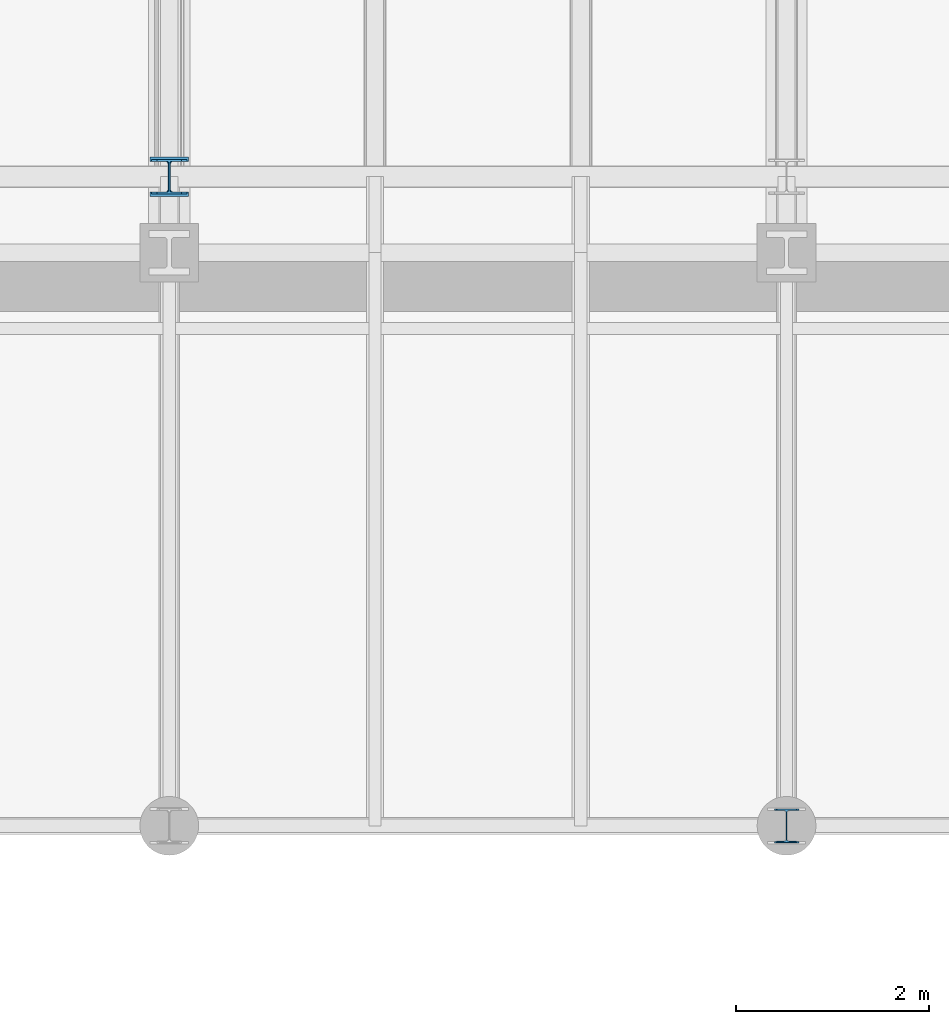
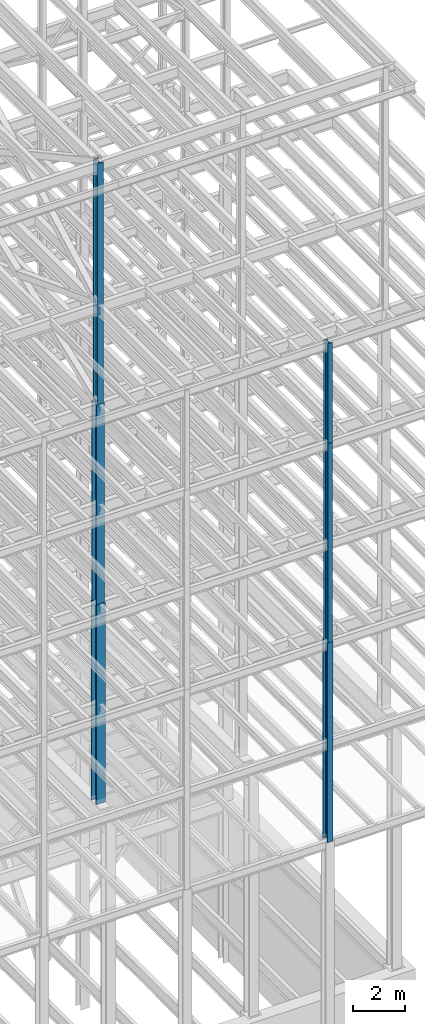
# One storey, part 80 of 150: 6 columns.
"""IFC2X3 building model written with IfcOpenShell, lengths in millimetres."""

from ifc_helpers import new_model, si_unit, frame, origin_with_axes, origin_2d_with_axis, place, context, subcontext, project, spatial, i_section, extrude, material, type_object, element, save


model = new_model("IFC2X3")

# Units and contexts
model_context = context("Model", 3, precision=1e-05, world=origin_with_axes())
body_context = subcontext(model_context, "Body", "Model", "MODEL_VIEW")
ifc_project = project(units=[si_unit("LENGTHUNIT", "METRE", prefix="MILLI"), si_unit("AREAUNIT", "SQUARE_METRE"), si_unit("VOLUMEUNIT", "CUBIC_METRE"), si_unit("MASSUNIT", "GRAM", prefix="KILO"), si_unit("TIMEUNIT", "SECOND"), si_unit("PLANEANGLEUNIT", "RADIAN"), si_unit("SOLIDANGLEUNIT", "STERADIAN"), si_unit("THERMODYNAMICTEMPERATUREUNIT", "DEGREE_CELSIUS"), si_unit("LUMINOUSINTENSITYUNIT", "LUMEN")], contexts=[model_context])

# Site, building, storey
site_placement = place(None, origin_with_axes())
site = spatial("IfcSite", under=ifc_project, at=site_placement, CompositionType="ELEMENT")
building_placement = place(site_placement, origin_with_axes())
building = spatial("IfcBuilding", under=site, at=building_placement, Name="Undefined", CompositionType="ELEMENT")
storey_placement = place(building_placement, origin_with_axes())
storey = spatial("IfcBuildingStorey", under=building, at=storey_placement, Name="Undefined", CompositionType="ELEMENT", Elevation=0.0)

# Columns
ifc_material = material(Name="STEEL/A992")
column_type_1 = type_object("IfcColumnType", Name="W14X43", PredefinedType="NOTDEFINED")
column_1_placement = place(storey_placement, frame((82194.4, 3454.4, 54482.99811024), z_axis=(0.0, 0.0, 1.0), x_axis=(1.0, 0.0, 0.0)))
element("IfcColumn", 1, at=column_1_placement, inside=storey, type_object=column_type_1, material=ifc_material, Name="COLUMN", ObjectType="W14X43", context=body_context, shape_type="SweptSolid", body=[
    extrude(i_section(OverallWidth=203.2, OverallDepth=346.075, WebThickness=7.9375, FlangeThickness=13.462, FilletRadius=21.4629, at=origin_2d_with_axis()), frame((0.0, 0.0, 4724.39999999999), z_axis=(0.0, 0.0, -1.0), x_axis=(-1.0, 0.0, 0.0)), (0.0, 0.0, 1.0), 4724.39999999999),
])
column_type_2 = type_object("IfcColumnType", Name="W14X61", PredefinedType="NOTDEFINED")
column_2_placement = place(storey_placement, frame((82194.4, 3454.4, 35585.39811024), z_axis=(0.0, 0.0, 1.0), x_axis=(1.0, 0.0, 0.0)))
element("IfcColumn", 2, at=column_2_placement, inside=storey, type_object=column_type_2, material=ifc_material, Name="COLUMN", ObjectType="W14X61", context=body_context, shape_type="SweptSolid", body=[
    extrude(i_section(OverallWidth=254.0, OverallDepth=352.425, WebThickness=9.5249, FlangeThickness=16.383, FilletRadius=21.717, at=origin_2d_with_axis()), frame((0.0, 0.0, 9448.8), z_axis=(0.0, 0.0, -1.0), x_axis=(-1.0, 0.0, 0.0)), (0.0, 0.0, 1.0), 9448.8),
])
column_type_3 = type_object("IfcColumnType", Name="W14X99", PredefinedType="NOTDEFINED")
column_3_placement = place(storey_placement, frame((75793.6, 10185.4, 45034.2009448801), z_axis=(0.0, 0.0, 1.0), x_axis=(1.0, 0.0, 0.0)))
element("IfcColumn", 3, at=column_3_placement, inside=storey, type_object=column_type_3, material=ifc_material, Name="COLUMN", ObjectType="W14X99", context=body_context, shape_type="SweptSolid", body=[
    extrude(i_section(OverallWidth=370.84, OverallDepth=358.775, WebThickness=12.6999, FlangeThickness=19.812, FilletRadius=32.5755, at=origin_2d_with_axis()), frame((0.0, 0.0, 9448.79905511992), z_axis=(0.0, 0.0, -1.0), x_axis=(-1.0, 0.0, 0.0)), (0.0, 0.0, 1.0), 9448.79905511991),
])
column_type_4 = type_object("IfcColumnType", Name="W14X74", PredefinedType="NOTDEFINED")
column_4_placement = place(storey_placement, frame((75793.6, 10185.4, 54483.0), z_axis=(0.0, 0.0, 1.0), x_axis=(1.0, 0.0, 0.0)))
element("IfcColumn", 4, at=column_4_placement, inside=storey, type_object=column_type_4, material=ifc_material, Name="COLUMN", ObjectType="W14X74", context=body_context, shape_type="SweptSolid", body=[
    extrude(i_section(OverallWidth=256.54, OverallDepth=358.775, WebThickness=11.1125, FlangeThickness=19.939, FilletRadius=21.336, at=origin_2d_with_axis()), frame((0.0, 0.0, 11430.0), z_axis=(0.0, 0.0, -1.0), x_axis=(-1.0, 0.0, 0.0)), (0.0, 0.0, 1.0), 11430.0),
])
column_type_5 = type_object("IfcColumnType", Name="W14X48", PredefinedType="NOTDEFINED")
column_5_placement = place(storey_placement, frame((82194.4, 3454.4, 45034.19811024), z_axis=(0.0, 0.0, 1.0), x_axis=(1.0, 0.0, 0.0)))
element("IfcColumn", 5, at=column_5_placement, inside=storey, type_object=column_type_5, material=ifc_material, Name="COLUMN", ObjectType="W14X48", context=body_context, shape_type="SweptSolid", body=[
    extrude(i_section(OverallWidth=203.962, OverallDepth=349.25, WebThickness=7.9375, FlangeThickness=15.113, FilletRadius=21.3994, at=origin_2d_with_axis()), frame((0.0, 0.0, 9448.8), z_axis=(0.0, 0.0, -1.0), x_axis=(-1.0, 0.0, 0.0)), (0.0, 0.0, 1.0), 9448.8),
])
column_type_6 = type_object("IfcColumnType", Name="W14X233", PredefinedType="NOTDEFINED")
column_6_placement = place(storey_placement, frame((75793.6, 10185.4, 35585.4), z_axis=(0.0, 0.0, 1.0), x_axis=(1.0, 0.0, 0.0)))
element("IfcColumn", 6, at=column_6_placement, inside=storey, type_object=column_type_6, material=ifc_material, Name="COLUMN", ObjectType="W14X233", context=body_context, shape_type="SweptSolid", body=[
    extrude(i_section(OverallWidth=403.86, OverallDepth=406.4, WebThickness=26.9875, FlangeThickness=43.688, FilletRadius=32.512, at=origin_2d_with_axis()), frame((0.0, 0.0, 9448.8009448801), z_axis=(0.0, 0.0, -1.0), x_axis=(-1.0, 0.0, 0.0)), (0.0, 0.0, 1.0), 9448.8009448801),
])

save(model, "model.ifc")
